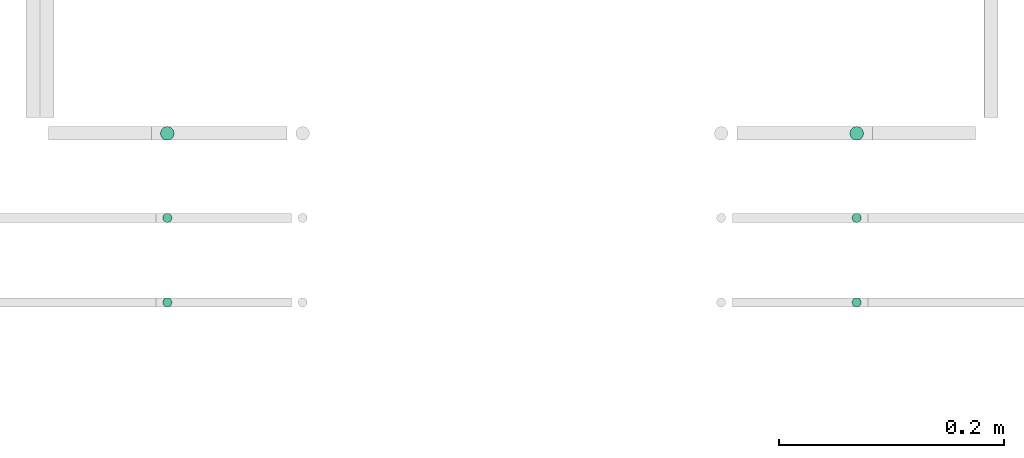
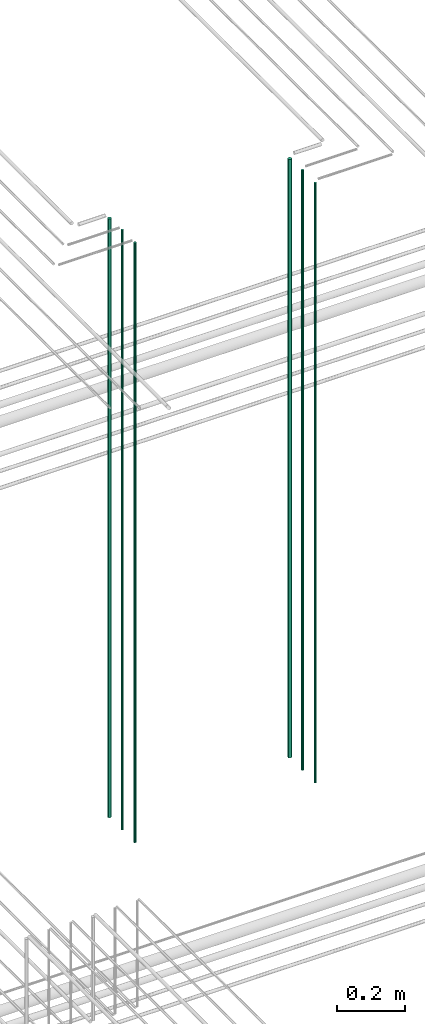
# One storey, part 18 of 331: 6 flow segments.
"""IFC2X3 building model written with IfcOpenShell, lengths in millimetres."""

from ifc_helpers import new_model, entity, si_unit, converted_unit, derived_unit, direction, frame, origin, origin_2d_with_axis, place, context, subcontext, project, spatial, circle, extrude, type_object, element, save


model = new_model("IFC2X3")

# Units and contexts
model_context = context("Model", 3, precision=0.01, world=origin(), true_north=direction((6.12303176911189e-17, 1.0)))
body_context = subcontext(model_context, "Body", "Model", "MODEL_VIEW")
ifc_project = project(units=[si_unit("LENGTHUNIT", "METRE", prefix="MILLI"), si_unit("AREAUNIT", "SQUARE_METRE"), si_unit("VOLUMEUNIT", "CUBIC_METRE"), converted_unit("PLANEANGLEUNIT", "DEGREE", entity("IfcRatioMeasure", 0.0174532925199433), si_unit("PLANEANGLEUNIT", "RADIAN"), dimensions=[0, 0, 0, 0, 0, 0, 0]), si_unit("MASSUNIT", "GRAM", prefix="KILO"), derived_unit("MASSDENSITYUNIT", [(si_unit("MASSUNIT", "GRAM", prefix="KILO"), 1), (si_unit("LENGTHUNIT", "METRE"), -3)]), derived_unit("MOMENTOFINERTIAUNIT", [(si_unit("LENGTHUNIT", "METRE"), 4)]), si_unit("TIMEUNIT", "SECOND"), si_unit("FREQUENCYUNIT", "HERTZ"), si_unit("THERMODYNAMICTEMPERATUREUNIT", "DEGREE_CELSIUS"), derived_unit("THERMALTRANSMITTANCEUNIT", [(si_unit("MASSUNIT", "GRAM", prefix="KILO"), 1), (si_unit("THERMODYNAMICTEMPERATUREUNIT", "KELVIN"), -1), (si_unit("TIMEUNIT", "SECOND"), -3)]), derived_unit("VOLUMETRICFLOWRATEUNIT", [(si_unit("LENGTHUNIT", "METRE"), 3), (si_unit("TIMEUNIT", "SECOND"), -1)]), derived_unit("MASSFLOWRATEUNIT", [(si_unit("MASSUNIT", "GRAM", prefix="KILO"), 1), (si_unit("TIMEUNIT", "SECOND"), -1)]), derived_unit("ROTATIONALFREQUENCYUNIT", [(si_unit("TIMEUNIT", "SECOND"), -1)]), si_unit("ELECTRICCURRENTUNIT", "AMPERE"), si_unit("ELECTRICVOLTAGEUNIT", "VOLT"), si_unit("POWERUNIT", "WATT"), si_unit("FORCEUNIT", "NEWTON", prefix="KILO"), si_unit("ILLUMINANCEUNIT", "LUX"), si_unit("LUMINOUSFLUXUNIT", "LUMEN"), si_unit("LUMINOUSINTENSITYUNIT", "CANDELA"), derived_unit("USERDEFINED", [(si_unit("MASSUNIT", "GRAM", prefix="KILO"), -1), (si_unit("LENGTHUNIT", "METRE"), -2), (si_unit("TIMEUNIT", "SECOND"), 3), (si_unit("LUMINOUSFLUXUNIT", "LUMEN"), 1)]), derived_unit("LINEARVELOCITYUNIT", [(si_unit("LENGTHUNIT", "METRE"), 1), (si_unit("TIMEUNIT", "SECOND"), -1)]), si_unit("PRESSUREUNIT", "PASCAL"), derived_unit("USERDEFINED", [(si_unit("LENGTHUNIT", "METRE"), -2), (si_unit("MASSUNIT", "GRAM", prefix="KILO"), 1), (si_unit("TIMEUNIT", "SECOND"), -2)]), derived_unit("LINEARFORCEUNIT", [(si_unit("MASSUNIT", "GRAM", prefix="KILO"), 1), (si_unit("LENGTHUNIT", "METRE"), 1), (si_unit("TIMEUNIT", "SECOND"), -2), (si_unit("LENGTHUNIT", "METRE"), -1)]), derived_unit("PLANARFORCEUNIT", [(si_unit("MASSUNIT", "GRAM", prefix="KILO"), 1), (si_unit("LENGTHUNIT", "METRE"), 1), (si_unit("TIMEUNIT", "SECOND"), -2), (si_unit("LENGTHUNIT", "METRE"), -2)])], contexts=[model_context])

# Site, building, storey
site_placement = place(None, frame((0.0, -0.00077364408347762, 0.0)))
site = spatial("IfcSite", under=ifc_project, at=site_placement, CompositionType="ELEMENT")
building_placement = place(site_placement, origin())
building = spatial("IfcBuilding", under=site, at=building_placement, CompositionType="ELEMENT")
storey_placement = place(building_placement, origin())
storey = spatial("IfcBuildingStorey", under=building, at=storey_placement, CompositionType="ELEMENT", Elevation=0.0)

# Flow segments
pipe_segment_type = type_object("IfcPipeSegmentType", PredefinedType="NOTDEFINED")
flow_segment_1_placement = place(storey_placement, frame((34657.8400837291, 3883.89349484379, 16890.0)))
element("IfcFlowSegment", 1, at=flow_segment_1_placement, inside=storey, type_object=pipe_segment_type, context=body_context, shape_type="SweptSolid", body=[
    extrude(circle(Radius=6.0, at=origin_2d_with_axis()), frame((7.59527223591454, 7.59527223591616, 0.0)), (0.0, 0.0, 1.0), 2146.0),
])
for number, where in (
    (2, (34659.8400837291, 3735.89349484379, 16890.0)),
    (3, (34659.8400837291, 3810.89349484379, 16890.0)),
):
    element("IfcFlowSegment", number, at=place(storey_placement, frame(where)), inside=storey, type_object=pipe_segment_type, context=body_context, shape_type="SweptSolid", body=[
        extrude(circle(Radius=4.0, at=origin_2d_with_axis()), frame((5.59527223591499, 5.59527223591607, 0.0)), (0.0, 0.0, 1.0), 2150.00000000001),
    ])
flow_segment_2_placement = place(storey_placement, frame((35269.3585217207, 3883.89349484379, 16890.0)))
element("IfcFlowSegment", 4, at=flow_segment_2_placement, inside=storey, type_object=pipe_segment_type, context=body_context, shape_type="SweptSolid", body=[
    extrude(circle(Radius=6.0, at=origin_2d_with_axis()), frame((7.59527223591454, 7.59527223591616, 0.0)), (0.0, 0.0, 1.0), 2146.0),
])
for number, where in (
    (5, (35271.3585217207, 3735.89349484379, 16890.0)),
    (6, (35271.3585217207, 3810.89349484379, 16890.0)),
):
    element("IfcFlowSegment", number, at=place(storey_placement, frame(where)), inside=storey, type_object=pipe_segment_type, context=body_context, shape_type="SweptSolid", body=[
        extrude(circle(Radius=4.0, at=origin_2d_with_axis()), frame((5.59527223591499, 5.59527223591607, 0.0)), (0.0, 0.0, 1.0), 2150.00000000001),
    ])

save(model, "model.ifc")
